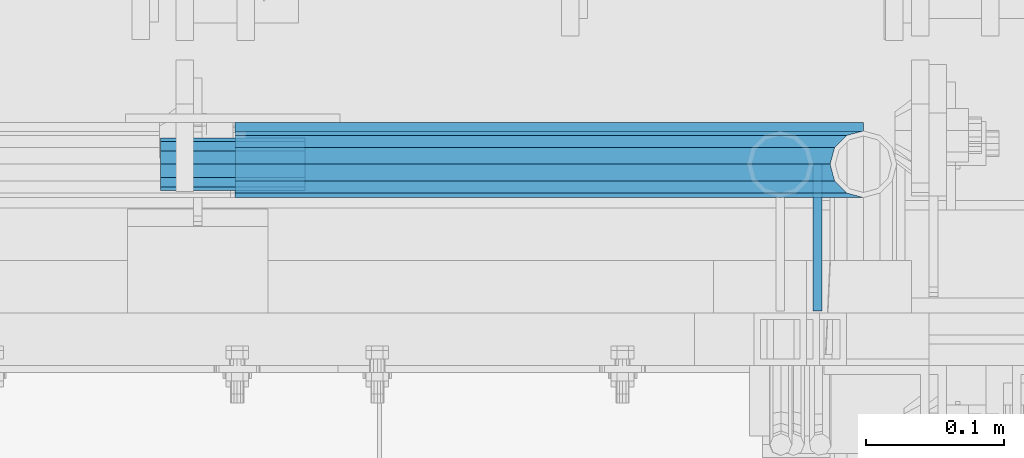
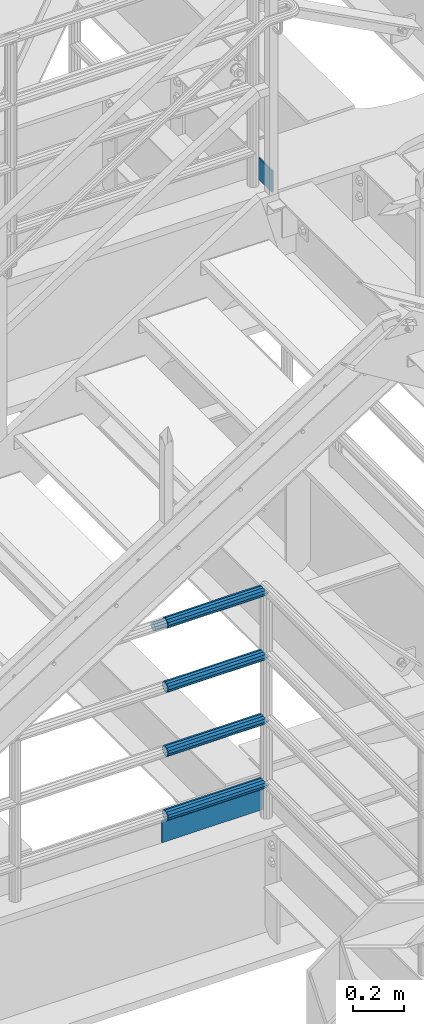
# One storey, part 1206 of 1876: 7 beams, 2 elements without a shape of their own.
"""IFC2X3 building model written with IfcOpenShell, lengths in millimetres."""

from ifc_helpers import new_model, si_unit, frame, origin_with_axes, place, context, subcontext, project, spatial, faceted_brep, material, type_object, element, aggregate, save


model = new_model("IFC2X3")

# Units and contexts
model_context = context("Model", 3, precision=1e-05, world=origin_with_axes())
body_context = subcontext(model_context, "Body", "Model", "MODEL_VIEW")
ifc_project = project(units=[si_unit("LENGTHUNIT", "METRE", prefix="MILLI"), si_unit("AREAUNIT", "SQUARE_METRE"), si_unit("VOLUMEUNIT", "CUBIC_METRE"), si_unit("MASSUNIT", "GRAM", prefix="KILO"), si_unit("TIMEUNIT", "SECOND"), si_unit("PLANEANGLEUNIT", "RADIAN"), si_unit("SOLIDANGLEUNIT", "STERADIAN"), si_unit("THERMODYNAMICTEMPERATUREUNIT", "DEGREE_CELSIUS"), si_unit("LUMINOUSINTENSITYUNIT", "LUMEN")], contexts=[model_context])

# Site, building, storey
site_placement = place(None, origin_with_axes())
site = spatial("IfcSite", under=ifc_project, at=site_placement, CompositionType="ELEMENT")
building_placement = place(site_placement, origin_with_axes())
building = spatial("IfcBuilding", under=site, at=building_placement, Name="Undefined", CompositionType="ELEMENT")
storey_placement = place(building_placement, origin_with_axes())
storey = spatial("IfcBuildingStorey", under=building, at=storey_placement, Name="Undefined", CompositionType="ELEMENT", Elevation=0.0)

# Assembly, beams
assembly_1_placement = place(storey_placement, origin_with_axes())
assembly_1 = element("IfcElementAssembly", 1, at=assembly_1_placement, inside=storey, Name="RAIL", AssemblyPlace="NOTDEFINED", PredefinedType="RIGID_FRAME")
ifc_material_1 = material()
beam_type_1 = type_object("IfcBeamType", Name="PIPE1-1/2SCH40", PredefinedType="NOTDEFINED")
beam_1_placement = place(assembly_1_placement, frame((6197.59999999999, -4654.55000114548, 5292.725), z_axis=(0.0, 0.0, -1.0), x_axis=(-1.0, 0.0, 0.0)))
beam_1 = element("IfcBeam", 2, at=beam_1_placement, type_object=beam_type_1, material=ifc_material_1, Name="RAIL", ObjectType="PIPE1-1/2SCH40", context=body_context, shape_type="Brep", body=[
    faceted_brep([(0.0, 24.1299999999992, 0.0), (12.0650000000064, 20.8971929933177, -12.0649999999987), (12.0650000000064, 20.8971929933177, 12.0649999999987), (12.0650000000064, -20.8971929933177, 12.0649999999987), (12.0650000000064, -20.8971929933177, -12.0649999999987), (0.0, -24.1299999999992, 0.0), (20.8971929933249, -12.0650000000005, 20.8971929933177), (20.8971929933249, -12.0650000000005, 15.8661214311796), (15.2545715621445, -17.7076214311801, 10.2235000000001), (12.5151929933249, -20.4470000000001, 0.0), (15.2545715621445, -17.7076214311801, -10.2235000000001), (20.8971929933249, -12.0650000000005, -15.8661214311796), (20.8971929933249, -12.0650000000005, -20.8971929933177), (24.1300000000063, 0.0, -20.4470000000001), (24.1300000000063, 0.0, -24.130000000001), (21.3906214311868, -10.2235000000001, -17.7076214311819), (21.3906214311868, 10.2235000000001, -17.7076214311819), (20.8971929933249, 12.0650000000005, -15.8661214311796), (20.8971929933249, 12.0650000000005, -20.8971929933177), (15.2545715621445, 17.7076214311801, -10.2235000000001), (12.5151929933249, 20.4470000000001, 0.0), (15.2545715621445, 17.7076214311801, 10.2235000000001), (20.8971929933249, 12.0650000000005, 15.8661214311796), (20.8971929933249, 12.0650000000005, 20.8971929933177), (21.3906214311868, 10.2235000000001, 17.7076214311819), (24.1300000000064, 0.0, 20.4470000000001), (24.1300000000064, 0.0, 24.130000000001), (21.3906214311868, -10.2235000000001, 17.7076214311819), (455.612999922148, -24.1300000000001, 0.0), (455.612999922148, -20.8971929933186, 12.0649999999996), (455.612999922148, -12.0649999999996, 20.8971929933186), (455.612999922148, 0.0, 24.1300000000001), (455.612999922148, -12.0649999999996, -20.8971929933186), (455.612999922148, -20.8971929933186, -12.0649999999996), (455.612999922148, 0.0, -24.1300000000001), (455.612999922148, 12.0649999999996, -20.8971929933186), (455.612999922148, 20.8971929933186, -12.0649999999996), (455.612999922148, 24.1300000000001, 0.0), (455.612999922148, 20.8971929933186, 12.0649999999996), (455.612999922148, 12.0649999999996, 20.8971929933186), (455.612999922148, -10.2235000000001, 17.7076214311801), (455.612999922148, 0.0, 20.4470000000001), (455.612999922148, 10.2235000000001, 17.7076214311801), (455.612999922148, 17.7076214311801, 10.2235000000001), (455.612999922148, 20.4470000000001, 0.0), (455.612999922148, 17.7076214311801, -10.2235000000001), (455.612999922148, 10.2235000000001, -17.7076214311801), (455.612999922148, 0.0, -20.4470000000001), (455.612999922148, -10.2235000000001, -17.7076214311801), (455.612999922148, -17.7076214311801, -10.2235000000001), (455.612999922148, -20.4470000000001, 0.0), (455.612999922148, -17.7076214311801, 10.2235000000001)], [[[0, 1, 2]], [[3, 4, 5]], [[6, 7, 8, 9, 10, 11, 12, 4, 3]], [[13, 14, 12, 11, 15]], [[16, 17, 18, 14, 13]], [[2, 1, 18, 17, 19, 20, 21, 22, 23]], [[23, 22, 24, 25, 26]], [[26, 25, 27, 7, 6]], [[28, 29, 3, 5]], [[29, 30, 6, 3]], [[30, 31, 26, 6]], [[32, 33, 4, 12]], [[34, 32, 12, 14]], [[35, 34, 14, 18]], [[36, 35, 18, 1]], [[37, 36, 1, 0]], [[38, 37, 0, 2]], [[39, 38, 2, 23]], [[31, 39, 23, 26]], [[33, 28, 5, 4]], [[32, 34, 35, 36, 37, 38, 39, 31, 30, 29, 28, 33], [40, 41, 42, 43, 44, 45, 46, 47, 48, 49, 50, 51]], [[42, 41, 25, 24]], [[21, 43, 42, 24, 22]], [[44, 43, 21, 20]], [[45, 44, 20, 19]], [[46, 45, 19, 17, 16]], [[47, 46, 16, 13]], [[48, 47, 13, 15]], [[10, 49, 48, 15, 11]], [[50, 49, 10, 9]], [[51, 50, 9, 8]], [[40, 51, 8, 7, 27]], [[41, 40, 27, 25]]]),
])
beam_2_placement = place(assembly_1_placement, frame((6197.59999999999, -4654.55000114548, 5597.525), z_axis=(0.0, 0.0, -1.0), x_axis=(-1.0, 0.0, 0.0)))
beam_2 = element("IfcBeam", 3, at=beam_2_placement, type_object=beam_type_1, material=ifc_material_1, Name="RAIL", ObjectType="PIPE1-1/2SCH40", context=body_context, shape_type="Brep", body=[
    faceted_brep([(0.0, 24.1299999999992, 0.0), (12.0650000000064, 20.8971929933177, -12.0649999999987), (12.0650000000064, 20.8971929933177, 12.0649999999987), (12.0650000000064, -20.8971929933177, 12.0649999999987), (12.0650000000064, -20.8971929933177, -12.0649999999987), (0.0, -24.1299999999992, 0.0), (20.8971929933249, -12.0650000000005, 20.8971929933177), (20.8971929933249, -12.0650000000005, 15.8661214311796), (15.2545715621445, -17.7076214311801, 10.2235000000001), (12.5151929933249, -20.4470000000001, 0.0), (15.2545715621445, -17.7076214311801, -10.2235000000001), (20.8971929933249, -12.0650000000005, -15.8661214311796), (20.8971929933249, -12.0650000000005, -20.8971929933177), (24.1300000000063, 0.0, -20.4470000000001), (24.1300000000063, 0.0, -24.130000000001), (21.3906214311868, -10.2235000000001, -17.7076214311819), (21.3906214311868, 10.2235000000001, -17.7076214311819), (20.8971929933249, 12.0650000000005, -15.8661214311796), (20.8971929933249, 12.0650000000005, -20.8971929933177), (15.2545715621445, 17.7076214311801, -10.2235000000001), (12.5151929933249, 20.4470000000001, 0.0), (15.2545715621445, 17.7076214311801, 10.2235000000001), (20.8971929933249, 12.0650000000005, 15.8661214311796), (20.8971929933249, 12.0650000000005, 20.8971929933177), (21.3906214311868, 10.2235000000001, 17.7076214311819), (24.1300000000064, 0.0, 20.4470000000001), (24.1300000000064, 0.0, 24.130000000001), (21.3906214311868, -10.2235000000001, 17.7076214311819), (455.612999922148, -24.1300000000001, 0.0), (455.612999922148, -20.8971929933186, 12.0649999999996), (455.612999922148, -12.0649999999996, 20.8971929933186), (455.612999922148, 0.0, 24.1300000000001), (455.612999922148, -12.0649999999996, -20.8971929933186), (455.612999922148, -20.8971929933186, -12.0649999999996), (455.612999922148, 0.0, -24.1300000000001), (455.612999922148, 12.0649999999996, -20.8971929933186), (455.612999922148, 20.8971929933186, -12.0649999999996), (455.612999922148, 24.1300000000001, 0.0), (455.612999922148, 20.8971929933186, 12.0649999999996), (455.612999922148, 12.0649999999996, 20.8971929933186), (455.612999922148, -10.2235000000001, 17.7076214311801), (455.612999922148, 0.0, 20.4470000000001), (455.612999922148, 10.2235000000001, 17.7076214311801), (455.612999922148, 17.7076214311801, 10.2235000000001), (455.612999922148, 20.4470000000001, 0.0), (455.612999922148, 17.7076214311801, -10.2235000000001), (455.612999922148, 10.2235000000001, -17.7076214311801), (455.612999922148, 0.0, -20.4470000000001), (455.612999922148, -10.2235000000001, -17.7076214311801), (455.612999922148, -17.7076214311801, -10.2235000000001), (455.612999922148, -20.4470000000001, 0.0), (455.612999922148, -17.7076214311801, 10.2235000000001)], [[[0, 1, 2]], [[3, 4, 5]], [[6, 7, 8, 9, 10, 11, 12, 4, 3]], [[13, 14, 12, 11, 15]], [[16, 17, 18, 14, 13]], [[2, 1, 18, 17, 19, 20, 21, 22, 23]], [[23, 22, 24, 25, 26]], [[26, 25, 27, 7, 6]], [[28, 29, 3, 5]], [[29, 30, 6, 3]], [[30, 31, 26, 6]], [[32, 33, 4, 12]], [[34, 32, 12, 14]], [[35, 34, 14, 18]], [[36, 35, 18, 1]], [[37, 36, 1, 0]], [[38, 37, 0, 2]], [[39, 38, 2, 23]], [[31, 39, 23, 26]], [[33, 28, 5, 4]], [[32, 34, 35, 36, 37, 38, 39, 31, 30, 29, 28, 33], [40, 41, 42, 43, 44, 45, 46, 47, 48, 49, 50, 51]], [[42, 41, 25, 24]], [[21, 43, 42, 24, 22]], [[44, 43, 21, 20]], [[45, 44, 20, 19]], [[46, 45, 19, 17, 16]], [[47, 46, 16, 13]], [[48, 47, 13, 15]], [[10, 49, 48, 15, 11]], [[50, 49, 10, 9]], [[51, 50, 9, 8]], [[40, 51, 8, 7, 27]], [[41, 40, 27, 25]]]),
])
beam_3_placement = place(assembly_1_placement, frame((6197.59999999999, -4654.55000114548, 5902.32500000001), z_axis=(0.0, 0.0, -1.0), x_axis=(-1.0, 0.0, 0.0)))
beam_3 = element("IfcBeam", 4, at=beam_3_placement, type_object=beam_type_1, material=ifc_material_1, Name="RAIL", ObjectType="PIPE1-1/2SCH40", context=body_context, shape_type="Brep", body=[
    faceted_brep([(0.0, 24.1299999999992, 0.0), (12.0650000000064, 20.8971929933177, -12.0649999999987), (12.0650000000064, 20.8971929933177, 12.0649999999987), (12.0650000000064, -20.8971929933177, 12.0649999999987), (12.0650000000064, -20.8971929933177, -12.0649999999987), (0.0, -24.1299999999992, 0.0), (20.8971929933249, -12.0650000000005, 20.8971929933177), (20.8971929933249, -12.0650000000005, 15.8661214311796), (15.2545715621445, -17.7076214311801, 10.2235000000001), (12.5151929933249, -20.4470000000001, 0.0), (15.2545715621445, -17.7076214311801, -10.2235000000001), (20.8971929933249, -12.0650000000005, -15.8661214311796), (20.8971929933249, -12.0650000000005, -20.8971929933177), (24.1300000000063, 0.0, -20.4470000000001), (24.1300000000063, 0.0, -24.130000000001), (21.3906214311868, -10.2235000000001, -17.7076214311819), (21.3906214311868, 10.2235000000001, -17.7076214311819), (20.8971929933249, 12.0650000000005, -15.8661214311796), (20.8971929933249, 12.0650000000005, -20.8971929933177), (15.2545715621445, 17.7076214311801, -10.2235000000001), (12.5151929933249, 20.4470000000001, 0.0), (15.2545715621445, 17.7076214311801, 10.2235000000001), (20.8971929933249, 12.0650000000005, 15.8661214311796), (20.8971929933249, 12.0650000000005, 20.8971929933177), (21.3906214311868, 10.2235000000001, 17.7076214311819), (24.1300000000064, 0.0, 20.4470000000001), (24.1300000000064, 0.0, 24.130000000001), (21.3906214311868, -10.2235000000001, 17.7076214311819), (455.612999922148, -24.1300000000001, 0.0), (455.612999922148, -20.8971929933186, 12.0649999999996), (455.612999922148, -12.0649999999996, 20.8971929933186), (455.612999922148, 0.0, 24.1300000000001), (455.612999922148, -12.0649999999996, -20.8971929933186), (455.612999922148, -20.8971929933186, -12.0649999999996), (455.612999922148, 0.0, -24.1300000000001), (455.612999922148, 12.0649999999996, -20.8971929933186), (455.612999922148, 20.8971929933186, -12.0649999999996), (455.612999922148, 24.1300000000001, 0.0), (455.612999922148, 20.8971929933186, 12.0649999999996), (455.612999922148, 12.0649999999996, 20.8971929933186), (455.612999922148, -10.2235000000001, 17.7076214311801), (455.612999922148, 0.0, 20.4470000000001), (455.612999922148, 10.2235000000001, 17.7076214311801), (455.612999922148, 17.7076214311801, 10.2235000000001), (455.612999922148, 20.4470000000001, 0.0), (455.612999922148, 17.7076214311801, -10.2235000000001), (455.612999922148, 10.2235000000001, -17.7076214311801), (455.612999922148, 0.0, -20.4470000000001), (455.612999922148, -10.2235000000001, -17.7076214311801), (455.612999922148, -17.7076214311801, -10.2235000000001), (455.612999922148, -20.4470000000001, 0.0), (455.612999922148, -17.7076214311801, 10.2235000000001)], [[[0, 1, 2]], [[3, 4, 5]], [[6, 7, 8, 9, 10, 11, 12, 4, 3]], [[13, 14, 12, 11, 15]], [[16, 17, 18, 14, 13]], [[2, 1, 18, 17, 19, 20, 21, 22, 23]], [[23, 22, 24, 25, 26]], [[26, 25, 27, 7, 6]], [[28, 29, 3, 5]], [[29, 30, 6, 3]], [[30, 31, 26, 6]], [[32, 33, 4, 12]], [[34, 32, 12, 14]], [[35, 34, 14, 18]], [[36, 35, 18, 1]], [[37, 36, 1, 0]], [[38, 37, 0, 2]], [[39, 38, 2, 23]], [[31, 39, 23, 26]], [[33, 28, 5, 4]], [[32, 34, 35, 36, 37, 38, 39, 31, 30, 29, 28, 33], [40, 41, 42, 43, 44, 45, 46, 47, 48, 49, 50, 51]], [[42, 41, 25, 24]], [[21, 43, 42, 24, 22]], [[44, 43, 21, 20]], [[45, 44, 20, 19]], [[46, 45, 19, 17, 16]], [[47, 46, 16, 13]], [[48, 47, 13, 15]], [[10, 49, 48, 15, 11]], [[50, 49, 10, 9]], [[51, 50, 9, 8]], [[40, 51, 8, 7, 27]], [[41, 40, 27, 25]]]),
])
beam_4_placement = place(assembly_1_placement, frame((6197.6, -4654.55000114554, 6207.125), z_axis=(0.0, 0.0, -1.0), x_axis=(-1.0, 0.0, 0.0)))
beam_4 = element("IfcBeam", 5, at=beam_4_placement, type_object=beam_type_1, material=ifc_material_1, Name="RAIL", ObjectType="PIPE1-1/2SCH40", context=body_context, shape_type="Brep", body=[
    faceted_brep([(0.0, 24.1299999999992, 0.0), (12.0650000000064, 20.8971929933177, -12.0649999999987), (12.0650000000064, 20.8971929933177, 12.0649999999987), (12.0650000000064, -20.8971929933177, 12.0649999999987), (12.0650000000064, -20.8971929933177, -12.0649999999987), (0.0, -24.1299999999992, 0.0), (20.8971929933249, -12.0650000000005, 20.8971929933177), (20.8971929933249, -12.0650000000005, 15.8661214311796), (15.2545715621445, -17.7076214311801, 10.2235000000001), (12.5151929933249, -20.4470000000001, 0.0), (15.2545715621445, -17.7076214311801, -10.2235000000001), (20.8971929933249, -12.0650000000005, -15.8661214311796), (20.8971929933249, -12.0650000000005, -20.8971929933177), (24.1300000000063, 0.0, -20.4470000000001), (24.1300000000063, 0.0, -24.130000000001), (21.3906214311868, -10.2235000000001, -17.7076214311819), (21.3906214311868, 10.2235000000001, -17.7076214311819), (20.8971929933249, 12.0650000000005, -15.8661214311796), (20.8971929933249, 12.0650000000005, -20.8971929933177), (15.2545715621445, 17.7076214311801, -10.2235000000001), (12.5151929933249, 20.4470000000001, 0.0), (15.2545715621445, 17.7076214311801, 10.2235000000001), (20.8971929933249, 12.0650000000005, 15.8661214311796), (20.8971929933249, 12.0650000000005, 20.8971929933177), (21.3906214311868, 10.2235000000001, 17.7076214311819), (24.1300000000064, 0.0, 20.4470000000001), (24.1300000000064, 0.0, 24.130000000001), (21.3906214311868, -10.2235000000001, 17.7076214311819), (455.612999922148, -24.1300000000001, 0.0), (455.612999922148, -20.8971929933186, 12.0649999999996), (455.612999922148, -12.0649999999996, 20.8971929933186), (455.612999922148, 0.0, 24.1300000000001), (455.612999922148, -12.0649999999996, -20.8971929933186), (455.612999922148, -20.8971929933186, -12.0649999999996), (455.612999922148, 0.0, -24.1300000000001), (455.612999922148, 12.0649999999996, -20.8971929933186), (455.612999922148, 20.8971929933186, -12.0649999999996), (455.612999922148, 24.1300000000001, 0.0), (455.612999922148, 20.8971929933186, 12.0649999999996), (455.612999922148, 12.0649999999996, 20.8971929933186), (455.612999922148, -10.2235000000001, 17.7076214311801), (455.612999922148, 0.0, 20.4470000000001), (455.612999922148, 10.2235000000001, 17.7076214311801), (455.612999922148, 17.7076214311801, 10.2235000000001), (455.612999922148, 20.4470000000001, 0.0), (455.612999922148, 17.7076214311801, -10.2235000000001), (455.612999922148, 10.2235000000001, -17.7076214311801), (455.612999922148, 0.0, -20.4470000000001), (455.612999922148, -10.2235000000001, -17.7076214311801), (455.612999922148, -17.7076214311801, -10.2235000000001), (455.612999922148, -20.4470000000001, 0.0), (455.612999922148, -17.7076214311801, 10.2235000000001)], [[[0, 1, 2]], [[3, 4, 5]], [[6, 7, 8, 9, 10, 11, 12, 4, 3]], [[13, 14, 12, 11, 15]], [[16, 17, 18, 14, 13]], [[2, 1, 18, 17, 19, 20, 21, 22, 23]], [[23, 22, 24, 25, 26]], [[26, 25, 27, 7, 6]], [[28, 29, 3, 5]], [[29, 30, 6, 3]], [[30, 31, 26, 6]], [[32, 33, 4, 12]], [[34, 32, 12, 14]], [[35, 34, 14, 18]], [[36, 35, 18, 1]], [[37, 36, 1, 0]], [[38, 37, 0, 2]], [[39, 38, 2, 23]], [[31, 39, 23, 26]], [[33, 28, 5, 4]], [[32, 34, 35, 36, 37, 38, 39, 31, 30, 29, 28, 33], [40, 41, 42, 43, 44, 45, 46, 47, 48, 49, 50, 51]], [[42, 41, 25, 24]], [[21, 43, 42, 24, 22]], [[44, 43, 21, 20]], [[45, 44, 20, 19]], [[46, 45, 19, 17, 16]], [[47, 46, 16, 13]], [[48, 47, 13, 15]], [[10, 49, 48, 15, 11]], [[50, 49, 10, 9]], [[51, 50, 9, 8]], [[40, 51, 8, 7, 27]], [[41, 40, 27, 25]]]),
])

# Assembly, beam
assembly_2_placement = place(storey_placement, origin_with_axes())
assembly_2 = element("IfcElementAssembly", 6, at=assembly_2_placement, inside=storey, Name="RAIL", AssemblyPlace="NOTDEFINED", PredefinedType="RIGID_FRAME")
ifc_material_2 = material(Name="STEEL/A36")
beam_type_2 = type_object("IfcBeamType", PredefinedType="NOTDEFINED")
beam_5_placement = place(assembly_2_placement, frame((6164.26249995291, -4654.55000111932, 8220.075), z_axis=(0.0, 0.0, 1.0), x_axis=(0.0, -1.0, 0.0)))
beam_5 = element("IfcBeam", 7, at=beam_5_placement, type_object=beam_type_2, material=ifc_material_2, Name="PLATE", context=body_context, shape_type="Brep", body=[
    faceted_brep([(0.0, 3.17500000000018, -50.8000000000002), (0.0, 3.17500000000018, 50.8000000000002), (106.362499666708, 3.17500000004748, 50.7999999999993), (106.362499666708, 3.17500000004748, -50.8000000000002), (0.0, -3.17500000000018, 50.8000000000002), (106.362499666709, -3.17499999995289, 50.7999999999993), (0.0, -3.17500000000018, -50.8000000000002), (106.362499666709, -3.17499999995289, -50.8000000000002)], [[[0, 1, 2, 3]], [[1, 4, 5, 2]], [[4, 6, 7, 5]], [[6, 0, 3, 7]], [[5, 7, 3, 2]], [[6, 4, 1, 0]]]),
])
aggregate(assembly_2, [beam_5])

# Beam
beam_6_placement = place(assembly_1_placement, frame((5740.40000007866, -4627.56250114114, 5197.47500025535), z_axis=(0.0, 0.0, 1.0), x_axis=(1.0, 0.0, 0.0)))
beam_6 = element("IfcBeam", 8, at=beam_6_placement, type_object=beam_type_2, material=ifc_material_2, Name="PLATE", context=body_context, shape_type="Brep", body=[
    faceted_brep([(1.58750000000009, 3.17500000000018, -50.8000000000002), (1.58750000000009, 3.17500000000018, 50.7999999999993), (457.200000688034, 3.17500000000018, 50.8000000000002), (457.200000688034, 3.17500000000018, -50.8000000000002), (1.58750000000009, -3.17500000000018, 50.7999999999993), (457.200000688034, -3.17500000000018, 50.8000000000002), (1.58750000000009, -3.17500000000018, -50.8000000000002), (457.200000688034, -3.17500000000018, -50.8000000000002)], [[[0, 1, 2, 3]], [[1, 4, 5, 2]], [[4, 6, 7, 5]], [[6, 0, 3, 7]], [[5, 7, 3, 2]], [[6, 4, 1, 0]]]),
])

beam_type_3 = type_object("IfcBeamType", PredefinedType="NOTDEFINED")
beam_7_placement = place(assembly_1_placement, frame((5792.78700007785, -4654.55004997361, 6207.12500000001), z_axis=(0.0, 0.0, 1.0), x_axis=(-1.0, 0.0, 0.0)))
beam_7 = element("IfcBeam", 9, at=beam_7_placement, type_object=beam_type_3, material=ifc_material_2, Name="ROD", context=body_context, shape_type="Brep", body=[
    faceted_brep([(0.0, -18.8594999999996, 0.0), (0.0, -16.3328061026723, -9.42975000000024), (104.774, -16.3328061026723, -9.42975000000024), (104.774, -18.8594999999996, 0.0), (0.0, -9.42975000000024, -16.3328061026723), (104.774, -9.42975000000024, -16.3328061026723), (0.0, 0.0, -18.8594999999996), (104.774, 0.0, -18.8594999999996), (0.0, 9.42975000000024, -16.3328061026723), (104.774, 9.42975000000024, -16.3328061026723), (0.0, 16.3328061026723, -9.42975000000024), (104.774, 16.3328061026723, -9.42975000000024), (0.0, 18.8594999999996, 0.0), (104.774, 18.8594999999996, 0.0), (0.0, 16.3328061026723, 9.42975000000024), (104.774, 16.3328061026723, 9.42975000000024), (0.0, 9.42975000000024, 16.3328061026723), (104.774, 9.42975000000024, 16.3328061026723), (0.0, 0.0, 18.8594999999996), (104.774, 0.0, 18.8594999999996), (0.0, -9.42975000000024, 16.3328061026723), (104.774, -9.42975000000024, 16.3328061026723), (0.0, -16.3328061026723, 9.42975000000024), (104.774, -16.3328061026723, 9.42975000000024)], [[[0, 1, 2, 3]], [[1, 4, 5, 2]], [[4, 6, 7, 5]], [[6, 8, 9, 7]], [[8, 10, 11, 9]], [[10, 12, 13, 11]], [[12, 14, 15, 13]], [[14, 16, 17, 15]], [[16, 18, 19, 17]], [[18, 20, 21, 19]], [[20, 22, 23, 21]], [[22, 0, 3, 23]], [[5, 7, 9, 11, 13, 15, 17, 19, 21, 23, 3, 2]], [[22, 20, 18, 16, 14, 12, 10, 8, 6, 4, 1, 0]]]),
])

aggregate(assembly_1, [beam_1, beam_2, beam_3, beam_7, beam_6, beam_4])

save(model, "model.ifc")
